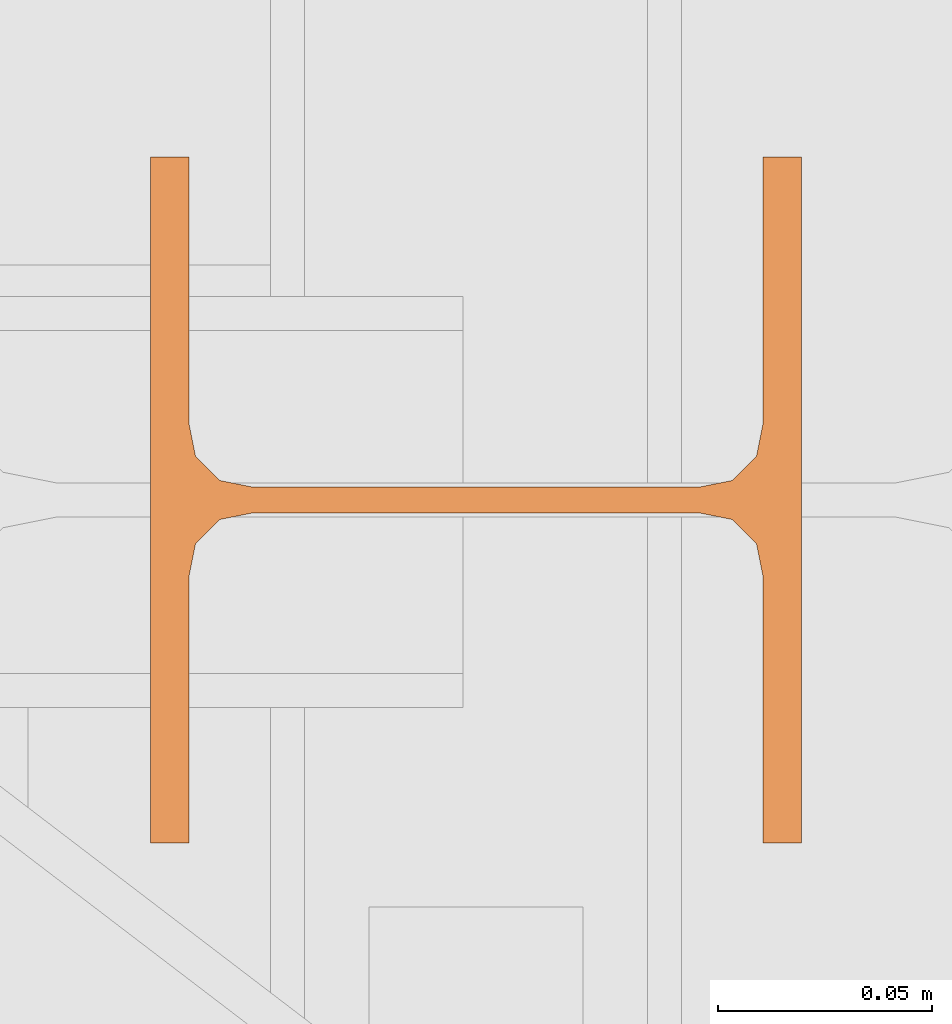
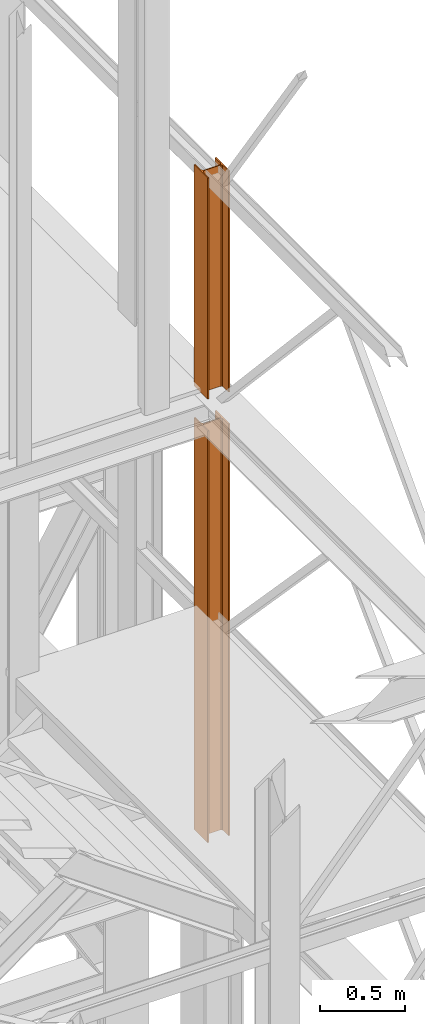
# One storey, part 61 of 208: 2 proxies.
"""IFC2X3 building model written with IfcOpenShell, lengths in millimetres."""

import ifcopenshell
import ifcopenshell.guid

model = None  # the IFC model being written
_history = None  # IfcOwnerHistory: only IFC2X3 demands one
_inside = {}  # id of a spatial element -> (the spatial element, [elements in it])
_under = {}  # id of a project, library or spatial element -> (it, [spatial elements below it])
_declared = {}  # id of a project -> (the project, [libraries it declares])
_typed = {}  # id of a type object -> (the type object, [elements of that type])
_made_of = {}  # id of a material, layer set ... -> (it, [elements and type objects made of it])


def new_model(schema):
    """Start an empty IFC model of exactly this schema.

    Asked for "IFC4X3", IfcOpenShell would pick the latest addendum, in which some entities
    have other attributes; the version numbers below select the first issue.
    IFC2X3 requires an IfcOwnerHistory on every rooted entity: one is made here for all.
    """
    global model, _history
    if schema == "IFC4X3":
        model = ifcopenshell.file(schema_version=(4, 3, 0, 0))
    else:
        model = ifcopenshell.file(schema=schema)
    _inside.clear()
    _under.clear()
    _declared.clear()
    _typed.clear()
    _made_of.clear()
    _history = None
    if model.schema == "IFC2X3":
        org = make("IfcOrganization", Name="unknown")
        user = make(
            "IfcPersonAndOrganization",
            ThePerson=make("IfcPerson", FamilyName="unknown"),
            TheOrganization=org,
        )
        app = make(
            "IfcApplication",
            ApplicationDeveloper=org,
            Version="unknown",
            ApplicationFullName="unknown",
            ApplicationIdentifier="unknown",
        )
        _history = make(
            "IfcOwnerHistory",
            OwningUser=user,
            OwningApplication=app,
            ChangeAction="ADDED",
            CreationDate=0,
        )
    return model


def make(cls, **values):
    """One entity of the class cls with the attributes given. An attribute that is None is left unset."""
    return model.create_entity(
        cls, **{name: value for name, value in values.items() if value is not None}
    )


def entity(cls, *values):
    """Any entity or typed value of the class cls, its attributes in the order of the schema. None: left unset."""
    e = model.create_entity(cls)
    for i, value in enumerate(values):
        if value is not None:
            e[i] = value
    return e


def rooted(cls, **values):
    """An entity with a GlobalId (a new one), such as an element, a storey or a relation."""
    return make(cls, GlobalId=ifcopenshell.guid.new(), OwnerHistory=_history, **values)


def si_unit(unit_type, name, prefix=None):
    """IfcSIUnit, for example si_unit("LENGTHUNIT", "METRE", prefix="MILLI")."""
    return make("IfcSIUnit", UnitType=unit_type, Prefix=prefix, Name=name)


def converted_unit(unit_type, name, factor, base, dimensions=None, offset=None):
    """IfcConversionBasedUnit, such as the inch: factor (a typed value) times the base unit."""
    return make(
        "IfcConversionBasedUnit"
        if offset is None
        else "IfcConversionBasedUnitWithOffset",
        ConversionOffset=offset,
        Dimensions=None
        if dimensions is None
        else entity("IfcDimensionalExponents", *dimensions),
        UnitType=unit_type,
        Name=name,
        ConversionFactor=make(
            "IfcMeasureWithUnit", ValueComponent=factor, UnitComponent=base
        ),
    )


def assignment(units):
    """IfcUnitAssignment: the units of a project."""
    return None if units is None else make("IfcUnitAssignment", Units=units)


def point(xyz):
    """IfcCartesianPoint."""
    return None if xyz is None else make("IfcCartesianPoint", Coordinates=xyz)


def direction(xyz):
    """IfcDirection."""
    return None if xyz is None else make("IfcDirection", DirectionRatios=xyz)


def frame(location, z_axis=None, x_axis=None):
    """IfcAxis2Placement3D, a coordinate frame: its origin and axes. An axis left out is left unset."""
    return make(
        "IfcAxis2Placement3D",
        Location=point(location),
        Axis=direction(z_axis),
        RefDirection=direction(x_axis),
    )


def origin():
    """The frame at (0, 0, 0) with its axes left unset."""
    return frame((0.0, 0.0, 0.0))


def origin_with_axes():
    """The frame at (0, 0, 0) with the z axis (0, 0, 1) and the x axis (1, 0, 0) written out."""
    return frame((0.0, 0.0, 0.0), z_axis=(0.0, 0.0, 1.0), x_axis=(1.0, 0.0, 0.0))


def place(relative_to, where):
    """IfcLocalPlacement: puts the frame where relative to a parent placement (None: the world)."""
    return make(
        "IfcLocalPlacement", PlacementRelTo=relative_to, RelativePlacement=where
    )


def context(
    kind, dimensions, precision=None, world=None, true_north=None, identifier=None
):
    """IfcGeometricRepresentationContext, for example the 3D "Model" context."""
    return make(
        "IfcGeometricRepresentationContext",
        ContextIdentifier=identifier,
        ContextType=kind,
        CoordinateSpaceDimension=dimensions,
        Precision=precision,
        WorldCoordinateSystem=world,
        TrueNorth=true_north,
    )


def subcontext(parent, identifier, kind, view, scale=None):
    """IfcGeometricRepresentationSubContext, for example "Body" below "Model"."""
    return make(
        "IfcGeometricRepresentationSubContext",
        ContextIdentifier=identifier,
        ContextType=kind,
        ParentContext=parent,
        TargetScale=scale,
        TargetView=view,
    )


def project(units=None, contexts=None):
    """IfcProject with its units and contexts."""
    return rooted(
        "IfcProject",
        Name="project",
        RepresentationContexts=contexts,
        UnitsInContext=assignment(units),
    )


def spatial(cls, under=None, at=None, **own):
    """A site, building, storey or space (cls), placed at a placement, below another one or the project."""
    s = rooted(cls, ObjectPlacement=at, **own)
    if under is not None:
        _under.setdefault(under.id(), (under, []))[1].append(s)
    return s


def faces_of(points, faces, orient=None, outer=None):
    """IfcFace entities. A face is a list of loops; a loop is a list of indices into points, from 0.

    orient and outer hold one flag for each loop. By default every Orientation is true, the
    first loop of a face is its IfcFaceOuterBound and the others are IfcFaceBound.
    """
    made = []
    for i, loops in enumerate(faces):
        bounds = []
        for j, loop in enumerate(loops):
            is_outer = j == 0 if outer is None else outer[i][j]
            bounds.append(
                make(
                    "IfcFaceOuterBound" if is_outer else "IfcFaceBound",
                    Bound=make("IfcPolyLoop", Polygon=[points[k] for k in loop]),
                    Orientation=True if orient is None else orient[i][j],
                )
            )
        made.append(make("IfcFace", Bounds=bounds))
    return made


def faceted_brep(points, faces, orient=None, outer=None, voids=None):
    """IfcFacetedBrep: a solid bounded by flat faces; with voids (closed shells), ...WithVoids."""
    shared = [point(p) for p in points]
    hull = make("IfcClosedShell", CfsFaces=faces_of(shared, faces, orient, outer))
    if voids is None:
        return make("IfcFacetedBrep", Outer=hull)
    return make(
        "IfcFacetedBrepWithVoids",
        Outer=hull,
        Voids=[
            make(cls, CfsFaces=faces_of(shared, fs, o, b)) for cls, fs, o, b in voids
        ],
    )


def shape(context_of_items, identifier, shape_type, items):
    """IfcShapeRepresentation: the items that make up one representation, for example the "Body"."""
    return make(
        "IfcShapeRepresentation",
        ContextOfItems=context_of_items,
        RepresentationIdentifier=identifier,
        RepresentationType=shape_type,
        Items=items,
    )


def made_of(thing, what):
    """Note that an element or type object is made of a material, layer set ...; save() writes the relation."""
    if what is not None:
        _made_of.setdefault(what.id(), (what, []))[1].append(thing)
    return thing


def element(
    cls,
    number,
    at=None,
    inside=None,
    cuts=None,
    type_object=None,
    material=None,
    context=None,
    identifier="Body",
    shape_type=None,
    held_by="IfcProductDefinitionShape",
    body=None,
    shapes=None,
    **own,
):
    """One element of the class cls, such as IfcWall. Its Tag is "e" and its number.

    at: its placement. inside: the storey or other place that contains it. cuts: it is an
    opening in that element (IfcRelVoidsElement). A single representation is given by context,
    identifier, shape_type and body (its items); several are given by shapes. held_by: the class
    of the entity that holds the representations. save() writes the other relations.
    """
    e = rooted(cls, Tag="e%d" % number, ObjectPlacement=at, **own)
    if body is not None:
        shapes = [shape(context, identifier, shape_type, body)]
    if shapes is not None:
        e.Representation = make(held_by, Representations=shapes)
    if inside is not None:
        _inside.setdefault(inside.id(), (inside, []))[1].append(e)
    if cuts is not None:
        rooted(
            "IfcRelVoidsElement", RelatingBuildingElement=cuts, RelatedOpeningElement=e
        )
    if type_object is not None:
        _typed.setdefault(type_object.id(), (type_object, []))[1].append(e)
    return made_of(e, material)


def aggregate(whole, parts):
    """IfcRelAggregates: a whole, such as a stair, and the parts it consists of."""
    return rooted("IfcRelAggregates", RelatingObject=whole, RelatedObjects=parts)


def save(model, path):
    """Write the relations noted so far, then the file.

    IfcRelAggregates (storeys below a building ...), IfcRelContainedInSpatialStructure (elements
    in a storey), IfcRelDefinesByType, IfcRelAssociatesMaterial and IfcRelDeclares: one each for
    every whole, place, type object, material and project.
    """
    for whole, parts in _under.values():
        aggregate(whole, parts)
    for where, things in _inside.values():
        rooted(
            "IfcRelContainedInSpatialStructure",
            RelatedElements=things,
            RelatingStructure=where,
        )
    for kind, things in _typed.values():
        rooted("IfcRelDefinesByType", RelatedObjects=things, RelatingType=kind)
    for what, things in _made_of.values():
        rooted("IfcRelAssociatesMaterial", RelatedObjects=things, RelatingMaterial=what)
    for by, libraries in _declared.values():
        rooted("IfcRelDeclares", RelatingContext=by, RelatedDefinitions=libraries)
    model.write(path)


model = new_model("IFC2X3")

# Units and contexts
model_context = context("Model", 3, precision=1e-05, world=origin())
plan_context = context("Plan", 3, precision=1e-05, world=origin())
body_context = subcontext(model_context, "Body", "Model", "MODEL_VIEW")
ifc_project = project(units=[si_unit("LENGTHUNIT", "METRE", prefix="MILLI"), converted_unit("PLANEANGLEUNIT", "DEGREE", entity("IfcPlaneAngleMeasure", 0.0174532925199433), si_unit("PLANEANGLEUNIT", "RADIAN"), dimensions=[0, 0, 0, 0, 0, 0, 0]), si_unit("AREAUNIT", "SQUARE_METRE"), si_unit("VOLUMEUNIT", "CUBIC_METRE")], contexts=[model_context, plan_context])

# Building, storey
building_placement = place(None, origin())
building = spatial("IfcBuilding", under=ifc_project, at=building_placement, CompositionType="COMPLEX")
storey_placement = place(building_placement, origin_with_axes())
storey = spatial("IfcBuildingStorey", under=building, at=storey_placement, Name="Geschoss", CompositionType="ELEMENT")

# Proxies
proxy_1_placement = place(storey_placement, frame((6622.254961659229, -22142.57439598033, 5284.990005364414), z_axis=(0.0, 0.0, 1.0), x_axis=(1.0, 0.0, 0.0)))
element("IfcBuildingElementProxy", 1, at=proxy_1_placement, inside=storey, context=body_context, shape_type="Brep", body=[
    faceted_brep([(152.0100100135805, 0.00999999999839929, 0.01000000000021828), (152.0100100135805, 160.0100113248809, 0.01000000000021828), (143.0100066757204, 160.0100113248809, 0.01000000000021828), (143.0100066757204, 98.01000675022442, 0.01000000000021828), (141.4562178945544, 90.24683052509863, 0.01000000000021828), (135.7731832361224, 84.56379586666662, 0.01000000000021828), (128.0100098049643, 83.01000568851669, 0.01000000000021828), (24.01000393390677, 83.01000568851669, 0.01000000000021828), (16.24682677745841, 84.56379586666662, 0.01000000000021828), (10.5637921190264, 90.24683052509863, 0.01000000000021828), (9.010003337860326, 98.01000675022442, 0.01000000000021828), (9.010003337860326, 160.0100113248809, 0.01000000000021828), (0.01000000000021828, 160.0100113248809, 0.01000000000021828), (0.01000000000021828, 0.00999999999839929, 0.01000000000021828), (9.010003337860326, 0.00999999999839929, 0.01000000000021828), (9.010003337860326, 62.01000457465489, 0.01000000000021828), (10.5637921190264, 69.77318079978068, 0.01000000000021828), (16.24682677745841, 75.45621545821268, 0.01000000000021828), (24.01000393390677, 77.01000563636262, 0.01000000000021828), (128.0100098049643, 77.01000563636262, 0.01000000000021828), (135.7731832361224, 75.45621545821268, 0.01000000000021828), (141.4562178945544, 69.77318079978068, 0.01000000000021828), (143.0100066757204, 62.01000457465489, 0.01000000000021828), (143.0100066757204, 0.00999999999839929, 0.01000000000021828), (152.0100100135805, 160.0100113248809, 0.01000000000021828), (152.0100100135805, 0.00999999999839929, 0.01000000000021828), (152.0100100135805, 0.00999999999839929, 2970.009992549421), (152.0100100135805, 160.0100113248809, 2970.009992549421), (143.0100066757204, 160.0100113248809, 0.01000000000021828), (152.0100100135805, 160.0100113248809, 0.01000000000021828), (152.0100100135805, 160.0100113248809, 2970.009992549421), (143.0100066757204, 160.0100113248809, 2970.009992549421), (143.0100066757204, 98.01000675022442, 0.01000000000021828), (143.0100066757204, 160.0100113248809, 0.01000000000021828), (143.0100066757204, 160.0100113248809, 2970.009992549421), (143.0100066757204, 98.01000675022442, 2970.009992549421), (141.4562178945544, 90.24683052509863, 0.01000000000021828), (143.0100066757204, 98.01000675022442, 0.01000000000021828), (143.0100066757204, 98.01000675022442, 2970.009992549421), (141.4562178945544, 90.24683052509863, 2970.009992549421), (135.7731832361224, 84.56379586666662, 0.01000000000021828), (141.4562178945544, 90.24683052509863, 0.01000000000021828), (141.4562178945544, 90.24683052509863, 2970.009992549421), (135.7731832361224, 84.56379586666662, 2970.009992549421), (128.0100098049643, 83.01000568851669, 0.01000000000021828), (135.7731832361224, 84.56379586666662, 0.01000000000021828), (135.7731832361224, 84.56379586666662, 2970.009992549421), (128.0100098049643, 83.01000568851669, 2970.009992549421), (24.01000393390677, 83.01000568851669, 0.01000000000021828), (128.0100098049643, 83.01000568851669, 0.01000000000021828), (128.0100098049643, 83.01000568851669, 2970.009992549421), (24.01000393390677, 83.01000568851669, 2970.009992549421), (16.24682677745841, 84.56379586666662, 0.01000000000021828), (24.01000393390677, 83.01000568851669, 0.01000000000021828), (24.01000393390677, 83.01000568851669, 2970.009992549421), (16.24682677745841, 84.56379586666662, 2970.009992549421), (10.5637921190264, 90.24683052509863, 0.01000000000021828), (16.24682677745841, 84.56379586666662, 0.01000000000021828), (16.24682677745841, 84.56379586666662, 2970.009992549421), (10.5637921190264, 90.24683052509863, 2970.009992549421), (9.010003337860326, 98.01000675022442, 0.01000000000021828), (10.5637921190264, 90.24683052509863, 0.01000000000021828), (10.5637921190264, 90.24683052509863, 2970.009992549421), (9.010003337860326, 98.01000675022442, 2970.009992549421), (9.010003337860326, 160.0100113248809, 0.01000000000021828), (9.010003337860326, 98.01000675022442, 0.01000000000021828), (9.010003337860326, 98.01000675022442, 2970.009992549421), (9.010003337860326, 160.0100113248809, 2970.009992549421), (0.01000000000021828, 160.0100113248809, 0.01000000000021828), (9.010003337860326, 160.0100113248809, 0.01000000000021828), (9.010003337860326, 160.0100113248809, 2970.009992549421), (0.01000000000021828, 160.0100113248809, 2970.009992549421), (0.01000000000021828, 0.00999999999839929, 0.01000000000021828), (0.01000000000021828, 160.0100113248809, 0.01000000000021828), (0.01000000000021828, 160.0100113248809, 2970.009992549421), (0.01000000000021828, 0.00999999999839929, 2970.009992549423), (9.010003337860326, 0.00999999999839929, 0.01000000000021828), (0.01000000000021828, 0.00999999999839929, 0.01000000000021828), (0.01000000000021828, 0.00999999999839929, 2970.009992549423), (9.010003337860326, 0.00999999999839929, 2970.009992549421), (9.010003337860326, 62.01000457465489, 0.01000000000021828), (9.010003337860326, 0.00999999999839929, 0.01000000000021828), (9.010003337860326, 0.00999999999839929, 2970.009992549421), (9.010003337860326, 62.01000457465489, 2970.009992549421), (10.5637921190264, 69.77318079978068, 0.01000000000021828), (9.010003337860326, 62.01000457465489, 0.01000000000021828), (9.010003337860326, 62.01000457465489, 2970.009992549421), (10.5637921190264, 69.77318079978068, 2970.009992549421), (16.24682677745841, 75.45621545821268, 0.01000000000021828), (10.5637921190264, 69.77318079978068, 0.01000000000021828), (10.5637921190264, 69.77318079978068, 2970.009992549421), (16.24682677745841, 75.45621545821268, 2970.009992549421), (24.01000393390677, 77.01000563636262, 0.01000000000021828), (16.24682677745841, 75.45621545821268, 0.01000000000021828), (16.24682677745841, 75.45621545821268, 2970.009992549421), (24.01000393390677, 77.01000563636262, 2970.009992549421), (128.0100098049643, 77.01000563636262, 0.01000000000021828), (24.01000393390677, 77.01000563636262, 0.01000000000021828), (24.01000393390677, 77.01000563636262, 2970.009992549421), (128.0100098049643, 77.01000563636262, 2970.009992549421), (135.7731832361224, 75.45621545821268, 0.01000000000021828), (128.0100098049643, 77.01000563636262, 0.01000000000021828), (128.0100098049643, 77.01000563636262, 2970.009992549421), (135.7731832361224, 75.45621545821268, 2970.009992549421), (141.4562178945544, 69.77318079978068, 0.01000000000021828), (135.7731832361224, 75.45621545821268, 0.01000000000021828), (135.7731832361224, 75.45621545821268, 2970.009992549421), (141.4562178945544, 69.77318079978068, 2970.009992549421), (143.0100066757204, 62.01000457465489, 0.01000000000021828), (141.4562178945544, 69.77318079978068, 0.01000000000021828), (141.4562178945544, 69.77318079978068, 2970.009992549421), (143.0100066757204, 62.01000457465489, 2970.009992549421), (143.0100066757204, 0.00999999999839929, 0.01000000000021828), (143.0100066757204, 62.01000457465489, 0.01000000000021828), (143.0100066757204, 62.01000457465489, 2970.009992549421), (143.0100066757204, 0.00999999999839929, 2970.009992549421), (152.0100100135805, 0.00999999999839929, 0.01000000000021828), (143.0100066757204, 0.00999999999839929, 0.01000000000021828), (143.0100066757204, 0.00999999999839929, 2970.009992549421), (152.0100100135805, 0.00999999999839929, 2970.009992549421), (152.0100100135805, 0.00999999999839929, 2970.009992549421), (143.0100066757204, 0.00999999999839929, 2970.009992549421), (143.0100066757204, 62.01000457465489, 2970.009992549421), (141.4562178945544, 69.77318079978068, 2970.009992549421), (135.7731832361224, 75.45621545821268, 2970.009992549421), (128.0100098049643, 77.01000563636262, 2970.009992549421), (24.01000393390677, 77.01000563636262, 2970.009992549421), (16.24682677745841, 75.45621545821268, 2970.009992549421), (10.5637921190264, 69.77318079978068, 2970.009992549421), (9.010003337860326, 62.01000457465489, 2970.009992549421), (9.010003337860326, 0.00999999999839929, 2970.009992549421), (0.01000000000021828, 0.00999999999839929, 2970.009992549423), (0.01000000000021828, 160.0100113248809, 2970.009992549421), (9.010003337860326, 160.0100113248809, 2970.009992549421), (9.010003337860326, 98.01000675022442, 2970.009992549421), (10.5637921190264, 90.24683052509863, 2970.009992549421), (16.24682677745841, 84.56379586666662, 2970.009992549421), (24.01000393390677, 83.01000568851669, 2970.009992549421), (128.0100098049643, 83.01000568851669, 2970.009992549421), (135.7731832361224, 84.56379586666662, 2970.009992549421), (141.4562178945544, 90.24683052509863, 2970.009992549421), (143.0100066757204, 98.01000675022442, 2970.009992549421), (143.0100066757204, 160.0100113248809, 2970.009992549421), (152.0100100135805, 160.0100113248809, 2970.009992549421)], [[[0, 1, 2, 3, 4, 5, 6, 7, 8, 9, 10, 11, 12, 13, 14, 15, 16, 17, 18, 19, 20, 21, 22, 23]], [[24, 25, 26, 27]], [[28, 29, 30, 31]], [[32, 33, 34, 35]], [[36, 37, 38, 39]], [[40, 41, 42, 43]], [[44, 45, 46, 47]], [[48, 49, 50, 51]], [[52, 53, 54, 55]], [[56, 57, 58, 59]], [[60, 61, 62, 63]], [[64, 65, 66, 67]], [[68, 69, 70, 71]], [[72, 73, 74, 75]], [[76, 77, 78, 79]], [[80, 81, 82, 83]], [[84, 85, 86, 87]], [[88, 89, 90, 91]], [[92, 93, 94, 95]], [[96, 97, 98, 99]], [[100, 101, 102, 103]], [[104, 105, 106, 107]], [[108, 109, 110, 111]], [[112, 113, 114, 115]], [[116, 117, 118, 119]], [[120, 121, 122, 123, 124, 125, 126, 127, 128, 129, 130, 131, 132, 133, 134, 135, 136, 137, 138, 139, 140, 141, 142, 143]]], orient=[[False], [False], [False], [False], [False], [False], [False], [False], [False], [False], [False], [False], [False], [False], [False], [False], [False], [False], [False], [False], [False], [False], [False], [False], [False], [False]]),
])
proxy_2_placement = place(storey_placement, frame((6622.254961659229, -22142.57439598033, 8484.990002086159), z_axis=(0.0, 0.0, 1.0), x_axis=(1.0, 0.0, 0.0)))
element("IfcBuildingElementProxy", 2, at=proxy_2_placement, inside=storey, context=body_context, shape_type="Brep", body=[
    faceted_brep([(152.0100100135805, 0.00999999999839929, 0.00999999999839929), (152.0100100135805, 160.0100113248809, 0.00999999999839929), (143.0100066757204, 160.0100113248809, 0.00999999999839929), (143.0100066757204, 98.01000675022442, 0.00999999999839929), (141.4562178945544, 90.24683052509863, 0.00999999999839929), (135.7731832361224, 84.56379586666662, 0.00999999999839929), (128.0100098049643, 83.01000568851669, 0.00999999999839929), (24.01000393390677, 83.01000568851669, 0.00999999999839929), (16.24682677745841, 84.56379586666662, 0.00999999999839929), (10.5637921190264, 90.24683052509863, 0.00999999999839929), (9.010003337860326, 98.01000675022442, 0.00999999999839929), (9.010003337860326, 160.0100113248809, 0.00999999999839929), (0.01000000000021828, 160.0100113248809, 0.00999999999839929), (0.01000000000021828, 0.00999999999839929, 0.00999999999839929), (9.010003337860326, 0.00999999999839929, 0.00999999999839929), (9.010003337860326, 62.01000457465489, 0.00999999999839929), (10.5637921190264, 69.77318079978068, 0.00999999999839929), (16.24682677745841, 75.45621545821268, 0.00999999999839929), (24.01000393390677, 77.01000563636262, 0.00999999999839929), (128.0100098049643, 77.01000563636262, 0.00999999999839929), (135.7731832361224, 75.45621545821268, 0.00999999999839929), (141.4562178945544, 69.77318079978068, 0.00999999999839929), (143.0100066757204, 62.01000457465489, 0.00999999999839929), (143.0100066757204, 0.00999999999839929, 0.00999999999839929), (152.0100100135805, 160.0100113248809, 0.00999999999839929), (152.0100100135805, 0.00999999999839929, 0.00999999999839929), (152.0100100135805, 0.00999999999839929, 1595.009998658896), (152.0100100135805, 160.0100113248809, 1595.009998658894), (143.0100066757204, 160.0100113248809, 0.00999999999839929), (152.0100100135805, 160.0100113248809, 0.00999999999839929), (152.0100100135805, 160.0100113248809, 1595.009998658894), (143.0100066757204, 160.0100113248809, 1595.009998658896), (143.0100066757204, 98.01000675022442, 0.00999999999839929), (143.0100066757204, 160.0100113248809, 0.00999999999839929), (143.0100066757204, 160.0100113248809, 1595.009998658896), (143.0100066757204, 98.01000675022442, 1595.009998658894), (141.4562178945544, 90.24683052509863, 0.00999999999839929), (143.0100066757204, 98.01000675022442, 0.00999999999839929), (143.0100066757204, 98.01000675022442, 1595.009998658894), (141.4562178945544, 90.24683052509863, 1595.009998658894), (135.7731832361224, 84.56379586666662, 0.00999999999839929), (141.4562178945544, 90.24683052509863, 0.00999999999839929), (141.4562178945544, 90.24683052509863, 1595.009998658894), (135.7731832361224, 84.56379586666662, 1595.009998658894), (128.0100098049643, 83.01000568851669, 0.00999999999839929), (135.7731832361224, 84.56379586666662, 0.00999999999839929), (135.7731832361224, 84.56379586666662, 1595.009998658894), (128.0100098049643, 83.01000568851669, 1595.009998658892), (24.01000393390677, 83.01000568851669, 0.00999999999839929), (128.0100098049643, 83.01000568851669, 0.00999999999839929), (128.0100098049643, 83.01000568851669, 1595.009998658892), (24.01000393390677, 83.01000568851669, 1595.009998658894), (16.24682677745841, 84.56379586666662, 0.00999999999839929), (24.01000393390677, 83.01000568851669, 0.00999999999839929), (24.01000393390677, 83.01000568851669, 1595.009998658894), (16.24682677745841, 84.56379586666662, 1595.009998658894), (10.5637921190264, 90.24683052509863, 0.00999999999839929), (16.24682677745841, 84.56379586666662, 0.00999999999839929), (16.24682677745841, 84.56379586666662, 1595.009998658894), (10.5637921190264, 90.24683052509863, 1595.009998658894), (9.010003337860326, 98.01000675022442, 0.00999999999839929), (10.5637921190264, 90.24683052509863, 0.00999999999839929), (10.5637921190264, 90.24683052509863, 1595.009998658894), (9.010003337861235, 98.01000675022442, 1595.009998658894), (9.010003337860326, 160.0100113248809, 0.00999999999839929), (9.010003337860326, 98.01000675022442, 0.00999999999839929), (9.010003337861235, 98.01000675022442, 1595.009998658894), (9.010003337860326, 160.0100113248809, 1595.009998658894), (0.01000000000021828, 160.0100113248809, 0.00999999999839929), (9.010003337860326, 160.0100113248809, 0.00999999999839929), (9.010003337860326, 160.0100113248809, 1595.009998658894), (0.01000000000021828, 160.0100113248809, 1595.009998658894), (0.01000000000021828, 0.00999999999839929, 0.00999999999839929), (0.01000000000021828, 160.0100113248809, 0.00999999999839929), (0.01000000000021828, 160.0100113248809, 1595.009998658894), (0.01000000000021828, 0.00999999999839929, 1595.009998658894), (9.010003337860326, 0.00999999999839929, 0.00999999999839929), (0.01000000000021828, 0.00999999999839929, 0.00999999999839929), (0.01000000000021828, 0.00999999999839929, 1595.009998658894), (9.010003337860326, 0.00999999999839929, 1595.009998658894), (9.010003337860326, 62.01000457465489, 0.00999999999839929), (9.010003337860326, 0.00999999999839929, 0.00999999999839929), (9.010003337860326, 0.00999999999839929, 1595.009998658894), (9.010003337860326, 62.01000457465489, 1595.009998658894), (10.5637921190264, 69.77318079978068, 0.00999999999839929), (9.010003337860326, 62.01000457465489, 0.00999999999839929), (9.010003337860326, 62.01000457465489, 1595.009998658894), (10.56379211902549, 69.77318079978068, 1595.009998658894), (16.24682677745841, 75.45621545821268, 0.00999999999839929), (10.5637921190264, 69.77318079978068, 0.00999999999839929), (10.56379211902549, 69.77318079978068, 1595.009998658894), (16.24682677745932, 75.45621545821268, 1595.009998658894), (24.01000393390677, 77.01000563636262, 0.00999999999839929), (16.24682677745841, 75.45621545821268, 0.00999999999839929), (16.24682677745932, 75.45621545821268, 1595.009998658894), (24.01000393390677, 77.01000563636262, 1595.009998658892), (128.0100098049643, 77.01000563636262, 0.00999999999839929), (24.01000393390677, 77.01000563636262, 0.00999999999839929), (24.01000393390677, 77.01000563636262, 1595.009998658892), (128.0100098049643, 77.01000563636262, 1595.009998658894), (135.7731832361224, 75.45621545821268, 0.00999999999839929), (128.0100098049643, 77.01000563636262, 0.00999999999839929), (128.0100098049643, 77.01000563636262, 1595.009998658894), (135.7731832361224, 75.45621545821268, 1595.009998658894), (141.4562178945544, 69.77318079978068, 0.00999999999839929), (135.7731832361224, 75.45621545821268, 0.00999999999839929), (135.7731832361224, 75.45621545821268, 1595.009998658894), (141.4562178945544, 69.77318079978068, 1595.009998658894), (143.0100066757204, 62.01000457465489, 0.00999999999839929), (141.4562178945544, 69.77318079978068, 0.00999999999839929), (141.4562178945544, 69.77318079978068, 1595.009998658894), (143.0100066757204, 62.01000457465489, 1595.009998658894), (143.0100066757204, 0.00999999999839929, 0.00999999999839929), (143.0100066757204, 62.01000457465489, 0.00999999999839929), (143.0100066757204, 62.01000457465489, 1595.009998658894), (143.0100066757204, 0.00999999999839929, 1595.009998658896), (152.0100100135805, 0.00999999999839929, 0.00999999999839929), (143.0100066757204, 0.00999999999839929, 0.00999999999839929), (143.0100066757204, 0.00999999999839929, 1595.009998658896), (152.0100100135805, 0.00999999999839929, 1595.009998658896), (0.01000000000021828, 0.00999999999839929, 1595.009998658894), (0.01000000000021828, 160.0100113248809, 1595.009998658894), (9.010003337860326, 160.0100113248809, 1595.009998658894), (9.010003337861235, 98.01000675022442, 1595.009998658894), (10.5637921190264, 90.24683052509863, 1595.009998658894), (16.24682677745841, 84.56379586666662, 1595.009998658894), (24.01000393390677, 83.01000568851669, 1595.009998658894), (128.0100098049643, 83.01000568851669, 1595.009998658892), (135.7731832361224, 84.56379586666662, 1595.009998658894), (141.4562178945544, 90.24683052509863, 1595.009998658894), (143.0100066757204, 98.01000675022442, 1595.009998658894), (143.0100066757204, 160.0100113248809, 1595.009998658896), (152.0100100135805, 160.0100113248809, 1595.009998658894), (152.0100100135805, 0.00999999999839929, 1595.009998658896), (143.0100066757204, 0.00999999999839929, 1595.009998658896), (143.0100066757204, 62.01000457465489, 1595.009998658894), (141.4562178945544, 69.77318079978068, 1595.009998658894), (135.7731832361224, 75.45621545821268, 1595.009998658894), (128.0100098049643, 77.01000563636262, 1595.009998658894), (24.01000393390677, 77.01000563636262, 1595.009998658892), (16.24682677745932, 75.45621545821268, 1595.009998658894), (10.56379211902549, 69.77318079978068, 1595.009998658894), (9.010003337860326, 62.01000457465489, 1595.009998658894), (9.010003337860326, 0.00999999999839929, 1595.009998658894)], [[[0, 1, 2, 3, 4, 5, 6, 7, 8, 9, 10, 11, 12, 13, 14, 15, 16, 17, 18, 19, 20, 21, 22, 23]], [[24, 25, 26, 27]], [[28, 29, 30, 31]], [[32, 33, 34, 35]], [[36, 37, 38, 39]], [[40, 41, 42, 43]], [[44, 45, 46, 47]], [[48, 49, 50, 51]], [[52, 53, 54, 55]], [[56, 57, 58, 59]], [[60, 61, 62, 63]], [[64, 65, 66, 67]], [[68, 69, 70, 71]], [[72, 73, 74, 75]], [[76, 77, 78, 79]], [[80, 81, 82, 83]], [[84, 85, 86, 87]], [[88, 89, 90, 91]], [[92, 93, 94, 95]], [[96, 97, 98, 99]], [[100, 101, 102, 103]], [[104, 105, 106, 107]], [[108, 109, 110, 111]], [[112, 113, 114, 115]], [[116, 117, 118, 119]], [[120, 121, 122, 123, 124, 125, 126, 127, 128, 129, 130, 131, 132, 133, 134, 135, 136, 137, 138, 139, 140, 141, 142, 143]]], orient=[[False], [False], [False], [False], [False], [False], [False], [False], [False], [False], [False], [False], [False], [False], [False], [False], [False], [False], [False], [False], [False], [False], [False], [False], [False], [False]]),
])

save(model, "model.ifc")
